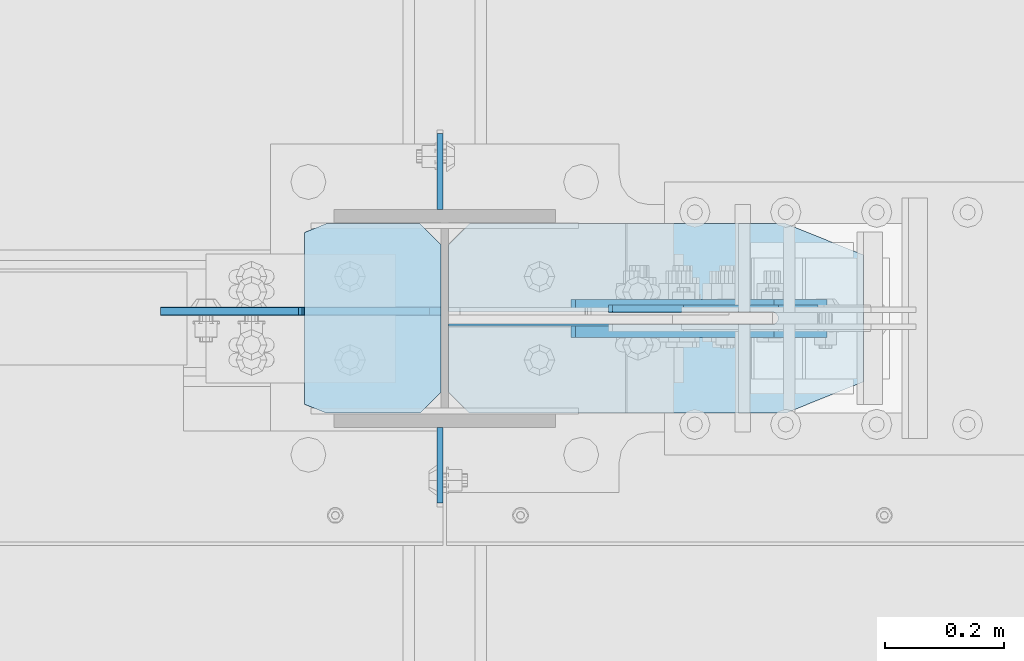
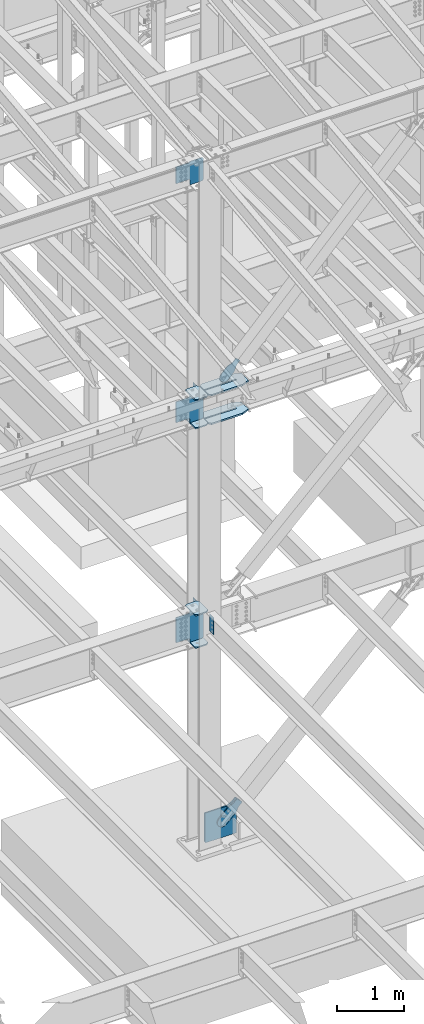
# One storey, part 1028 of 1179: 16 plates, 4 elements without a shape of their own.
"""IFC2X3 building model written with IfcOpenShell, lengths in millimetres."""

from ifc_helpers import new_model, si_unit, frame, origin_with_axes, place, context, subcontext, project, spatial, faceted_brep, material, type_object, element, aggregate, save


model = new_model("IFC2X3")

# Units and contexts
model_context = context("Model", 3, precision=1e-05, world=origin_with_axes())
body_context = subcontext(model_context, "Body", "Model", "MODEL_VIEW")
ifc_project = project(units=[si_unit("LENGTHUNIT", "METRE", prefix="MILLI"), si_unit("AREAUNIT", "SQUARE_METRE"), si_unit("VOLUMEUNIT", "CUBIC_METRE"), si_unit("MASSUNIT", "GRAM", prefix="KILO"), si_unit("TIMEUNIT", "SECOND"), si_unit("PLANEANGLEUNIT", "RADIAN"), si_unit("SOLIDANGLEUNIT", "STERADIAN"), si_unit("THERMODYNAMICTEMPERATUREUNIT", "DEGREE_CELSIUS"), si_unit("LUMINOUSINTENSITYUNIT", "LUMEN")], contexts=[model_context])

# Site, building, storey
site_placement = place(None, origin_with_axes())
site = spatial("IfcSite", under=ifc_project, at=site_placement, CompositionType="ELEMENT")
building_placement = place(site_placement, origin_with_axes())
building = spatial("IfcBuilding", under=site, at=building_placement, Name="Undefined", CompositionType="ELEMENT")
storey_placement = place(building_placement, origin_with_axes())
storey = spatial("IfcBuildingStorey", under=building, at=storey_placement, Name="Undefined", CompositionType="ELEMENT", Elevation=0.0)

# Assembly, plates
assembly_1_placement = place(storey_placement, origin_with_axes())
assembly_1 = element("IfcElementAssembly", 1, at=assembly_1_placement, inside=storey, Name="COLUMN", AssemblyPlace="NOTDEFINED", PredefinedType="RIGID_FRAME")
ifc_material_1 = material(Name="STEEL/A36")
plate_type_1 = type_object("IfcPlateType", PredefinedType="NOTDEFINED")
plate_1_placement = place(assembly_1_placement, frame((8272.4625, 27233.5625, 7975.59999886453), z_axis=(0.0, 1.0, 0.0), x_axis=(0.0, 0.0, -1.0)))
plate_1 = element("IfcPlate", 2, at=plate_1_placement, type_object=plate_type_1, material=ifc_material_1, Name="PLATE", context=body_context, shape_type="Brep", body=[
    faceted_brep([(0.0, -4.76249999999709, 0.0), (0.0, -4.76249999999709, 127.0), (0.0, 4.76249999999709, 127.0), (0.0, 4.76249999999709, 0.0), (304.799999999999, -4.76249999999982, 127.0), (304.799999999999, 4.76249999999982, 127.0), (304.799987792969, -4.76250000000073, 0.0), (304.799987792969, 4.76250000000073, 0.0)], [[[0, 1, 2, 3]], [[2, 1, 4, 5]], [[4, 6, 7, 5]], [[6, 0, 3, 7]], [[5, 7, 3, 2]], [[6, 4, 1, 0]]]),
])
plate_2_placement = place(assembly_1_placement, frame((8272.4625, 26868.4375, 4063.99999886453), z_axis=(0.0, -1.0, 0.0), x_axis=(0.0, 0.0, -1.0)))
plate_2 = element("IfcPlate", 3, at=plate_2_placement, type_object=plate_type_1, material=ifc_material_1, Name="PLATE", context=body_context, shape_type="Brep", body=[
    faceted_brep([(0.0, -4.76249999999709, 0.0), (0.0, -4.76249999999709, 127.0), (0.0, 4.76249999999709, 127.0), (0.0, 4.76249999999709, 0.0), (304.799999999999, -4.76249999999982, 127.0), (304.799999999999, 4.76249999999982, 127.0), (304.799987792969, -4.76250000000073, 0.0), (304.799987792969, 4.76250000000073, 0.0)], [[[0, 1, 2, 3]], [[2, 1, 4, 5]], [[4, 6, 7, 5]], [[6, 0, 3, 7]], [[5, 7, 3, 2]], [[6, 4, 1, 0]]]),
])
plate_3_placement = place(assembly_1_placement, frame((8272.4625, 27233.5625, 4063.99999886453), z_axis=(0.0, 1.0, 0.0), x_axis=(0.0, 0.0, -1.0)))
plate_3 = element("IfcPlate", 4, at=plate_3_placement, type_object=plate_type_1, material=ifc_material_1, Name="PLATE", context=body_context, shape_type="Brep", body=[
    faceted_brep([(0.0, -4.76249999999709, 0.0), (0.0, -4.76250000000073, 127.109008789062), (0.0, 4.76250000000073, 127.109008789062), (0.0, 4.76249999999709, 0.0), (304.799987792969, -4.76250000000073, 127.109008789062), (304.799987792969, 4.76250000000073, 127.109008789062), (304.799987792969, -4.76250000000073, 0.0), (304.799987792969, 4.76250000000073, 0.0)], [[[0, 1, 2, 3]], [[1, 4, 5, 2]], [[4, 6, 7, 5]], [[6, 0, 3, 7]], [[5, 7, 3, 2]], [[6, 4, 1, 0]]]),
])

# Assembly, plate
assembly_2_placement = place(storey_placement, origin_with_axes())
assembly_2 = element("IfcElementAssembly", 5, at=assembly_2_placement, inside=storey, AssemblyPlace="NOTDEFINED", PredefinedType="RIGID_FRAME")
plate_type_2 = type_object("IfcPlateType", PredefinedType="NOTDEFINED")
plate_4_placement = place(assembly_2_placement, frame((8848.95548700398, 27066.875, 8270.04204745431), z_axis=(-0.724386095169387, 0.0, 0.689394506161203), x_axis=(0.689394506161203, 0.0, 0.724386095169387)))
plate_4 = element("IfcPlate", 6, at=plate_4_placement, type_object=plate_type_2, material=ifc_material_1, context=body_context, shape_type="Brep", body=[
    faceted_brep([(0.0, -6.34999999999854, 0.0), (-101.600000000211, -6.34999999999854, -44.6881937825565), (-101.600000000211, 6.34999999999854, -44.6881937825565), (0.0, 6.34999999999854, 0.0), (-246.684985848258, -6.34999999999854, -44.6881937827675), (-246.684985848258, 6.34999999999854, -44.6881937827675), (-281.313054102191, -6.34999999999854, -37.800242748639), (-281.313054102191, 6.34999999999854, -37.800242748639), (-310.669312868691, -6.34999999999854, -18.1850177516608), (-310.669312868691, 6.34999999999854, -18.1850177516608), (-330.284537865713, -6.34999999999854, 11.1712410148393), (-330.284537865713, 6.34999999999854, 11.1712410148393), (-337.172488899912, -6.34999999999854, 45.7993031647638), (-337.172488899912, 6.34999999999854, 45.7993031647638), (-330.284537865768, -6.34999999999854, 80.4273714187839), (-330.284537865768, 6.34999999999854, 80.4273714187839), (-310.669312868773, -6.34999999999854, 109.783630185371), (-310.669312868773, 6.34999999999854, 109.783630185371), (-281.313054102271, -6.34999999999854, 129.398855182466), (-281.313054102271, 6.34999999999854, 129.398855182466), (-246.684988899762, -6.34999999999854, 136.286806216707), (-246.684988899762, 6.34999999999854, 136.286806216707), (-101.600000000377, -6.34999999999854, 136.286806216911), (-101.600000000377, 6.34999999999854, 136.286806216911), (-8.18545231595635e-11, -6.34999999999854, 91.5986124346418), (-8.18545231595635e-11, 6.34999999999854, 91.5986124346418), (82.5500000001266, -6.34999999999854, 91.5986124347546), (82.5500000001266, 6.34999999999854, 91.5986124347546), (82.550000000203, -6.34999999999854, 1.2732925824821e-10), (82.550000000203, 6.34999999999854, 1.2732925824821e-10)], [[[0, 1, 2, 3]], [[1, 4, 5, 2]], [[4, 6, 7, 5]], [[6, 8, 9, 7]], [[8, 10, 11, 9]], [[10, 12, 13, 11]], [[12, 14, 15, 13]], [[14, 16, 17, 15]], [[16, 18, 19, 17]], [[18, 20, 21, 19]], [[20, 22, 23, 21]], [[22, 24, 25, 23]], [[24, 26, 27, 25]], [[26, 28, 29, 27]], [[28, 0, 3, 29]], [[5, 7, 9, 11, 13, 15, 17, 19, 21, 23, 25, 27, 29, 3, 2]], [[28, 26, 24, 22, 20, 18, 16, 14, 12, 10, 8, 6, 4, 1, 0]]]),
])
aggregate(assembly_2, [plate_4])

# Plate
ifc_material_2 = material(Name="STEEL/A572-GR.50")
plate_type_3 = type_object("IfcPlateType", PredefinedType="NOTDEFINED")
plate_5_placement = place(assembly_1_placement, frame((8045.45, 27209.75, 7491.4125), z_axis=(0.0, -1.0, 0.0), x_axis=(1.0, 0.0, 0.0)))
plate_5 = element("IfcPlate", 7, at=plate_5_placement, type_object=plate_type_3, material=ifc_material_2, Name="PLATE", context=body_context, shape_type="Brep", body=[
    faceted_brep([(36.5125000000007, -11.1124999999993, 0.0), (0.0, -11.1124999999993, 14.6049999999996), (0.0, 11.1124999999993, 14.6049999999996), (36.5125000000007, 11.1124999999993, 0.0), (36.5125000000007, -11.1124999999993, 317.5), (36.5125000000007, 11.1124999999993, 317.5), (0.0, 11.1124999999993, 302.895), (0.0, -11.1124999999993, 302.895), (193.675000762942, -11.1124999999993, 317.5), (193.675000762942, 11.1124999999993, 317.5), (228.600000000002, -11.1124999999993, 282.575000762939), (228.600000000002, 11.1124999999993, 282.575000762939), (228.600000000002, -11.1124999999993, 34.9249992370605), (228.600000000002, 11.1124999999993, 34.9249992370605), (193.675000762942, -11.1124999999993, 0.0), (193.675000762942, 11.1124999999993, 0.0)], [[[0, 1, 2, 3]], [[4, 5, 6, 7]], [[8, 9, 5, 4]], [[8, 10, 11, 9]], [[10, 12, 13, 11]], [[12, 14, 15, 13]], [[15, 14, 0, 3]], [[6, 5, 9, 11, 13, 15, 3, 2]], [[7, 6, 2, 1]], [[14, 12, 10, 8, 4, 7, 1, 0]]]),
])

plate_6_placement = place(assembly_1_placement, frame((8045.45, 27209.75, 8002.5875), z_axis=(0.0, -1.0, 0.0), x_axis=(1.0, 0.0, 0.0)))
plate_6 = element("IfcPlate", 8, at=plate_6_placement, type_object=plate_type_3, material=ifc_material_2, Name="PLATE", context=body_context, shape_type="Brep", body=[
    faceted_brep([(36.5125000000007, -11.1124999999993, 0.0), (0.0, -11.1124999999993, 14.6049999999996), (0.0, 11.1124999999993, 14.6049999999996), (36.5125000000007, 11.1124999999993, 0.0), (36.5125000000007, -11.1124999999993, 317.5), (36.5125000000007, 11.1124999999993, 317.5), (0.0, 11.1124999999993, 302.895), (0.0, -11.1124999999993, 302.895), (193.675000762942, -11.1124999999993, 317.5), (193.675000762942, 11.1124999999993, 317.5), (228.600000000002, -11.1124999999993, 282.575000762939), (228.600000000002, 11.1124999999993, 282.575000762939), (228.600000000002, -11.1124999999993, 34.9249992370605), (228.600000000002, 11.1124999999993, 34.9249992370605), (193.675000762942, -11.1124999999993, 0.0), (193.675000762942, 11.1124999999993, 0.0)], [[[0, 1, 2, 3]], [[4, 5, 6, 7]], [[8, 9, 5, 4]], [[8, 10, 11, 9]], [[10, 12, 13, 11]], [[12, 14, 15, 13]], [[15, 14, 0, 3]], [[6, 5, 9, 11, 13, 15, 3, 2]], [[7, 6, 2, 1]], [[14, 12, 10, 8, 4, 7, 1, 0]]]),
])

plate_7_placement = place(assembly_1_placement, frame((8045.45, 27209.75, 3500.4375), z_axis=(0.0, -1.0, 0.0), x_axis=(1.0, 0.0, 0.0)))
plate_7 = element("IfcPlate", 9, at=plate_7_placement, type_object=plate_type_3, material=ifc_material_2, Name="PLATE", context=body_context, shape_type="Brep", body=[
    faceted_brep([(36.5125000000007, -11.1124999999993, 0.0), (0.0, -11.1125000000002, 14.979486697699), (0.0, 11.1125000000002, 14.979486697699), (36.5125000000007, 11.1124999999993, 0.0), (36.5125000000007, -11.1124999999993, 317.5), (36.5125000000007, 11.1124999999993, 317.5), (0.0, 11.1125000000002, 302.520512676303), (0.0, -11.1125000000002, 302.520512676303), (193.675000762942, -11.1124999999993, 317.5), (193.675000762942, 11.1124999999993, 317.5), (228.600000000002, -11.1124999999993, 282.575000762939), (228.600000000002, 11.1124999999993, 282.575000762939), (228.600000000002, -11.1124999999993, 34.9249992370605), (228.600000000002, 11.1124999999993, 34.9249992370605), (193.675000762942, -11.1124999999993, 0.0), (193.675000762942, 11.1124999999993, 0.0)], [[[0, 1, 2, 3]], [[4, 5, 6, 7]], [[8, 9, 5, 4]], [[8, 10, 11, 9]], [[10, 12, 13, 11]], [[12, 14, 15, 13]], [[15, 14, 0, 3]], [[6, 5, 9, 11, 13, 15, 3, 2]], [[7, 6, 2, 1]], [[14, 12, 10, 8, 4, 7, 1, 0]]]),
])

plate_8_placement = place(assembly_1_placement, frame((8045.45, 27209.75, 4090.9875), z_axis=(0.0, -1.0, 0.0), x_axis=(1.0, 0.0, 0.0)))
plate_8 = element("IfcPlate", 10, at=plate_8_placement, type_object=plate_type_3, material=ifc_material_2, Name="PLATE", context=body_context, shape_type="Brep", body=[
    faceted_brep([(36.5125000000007, -11.1124999999993, 0.0), (0.0, -11.1125000000002, 14.979486697699), (0.0, 11.1125000000002, 14.979486697699), (36.5125000000007, 11.1124999999993, 0.0), (36.5125000000007, -11.1124999999993, 317.5), (36.5125000000007, 11.1124999999993, 317.5), (0.0, 11.1125000000002, 302.520512676303), (0.0, -11.1125000000002, 302.520512676303), (193.675000762942, -11.1124999999993, 317.5), (193.675000762942, 11.1124999999993, 317.5), (228.600000000002, -11.1124999999993, 282.575000762939), (228.600000000002, 11.1124999999993, 282.575000762939), (228.600000000002, -11.1124999999993, 34.9249992370605), (228.600000000002, 11.1124999999993, 34.9249992370605), (193.675000762942, -11.1124999999993, 0.0), (193.675000762942, 11.1124999999993, 0.0)], [[[0, 1, 2, 3]], [[4, 5, 6, 7]], [[8, 9, 5, 4]], [[8, 10, 11, 9]], [[10, 12, 13, 11]], [[12, 14, 15, 13]], [[15, 14, 0, 3]], [[6, 5, 9, 11, 13, 15, 3, 2]], [[7, 6, 2, 1]], [[14, 12, 10, 8, 4, 7, 1, 0]]]),
])

plate_type_4 = type_object("IfcPlateType", PredefinedType="NOTDEFINED")
plate_9_placement = place(assembly_1_placement, frame((8274.04999661162, 27062.9062499701, 11843.9406250357), z_axis=(-0.707106781186532, 0.0, 0.707106781186563), x_axis=(-0.707106781186564, 0.0, -0.707106781186531)))
plate_9 = element("IfcPlate", 11, at=plate_9_placement, type_object=plate_type_4, material=ifc_material_2, Name="PLATE", context=body_context, shape_type="Brep", body=[
    faceted_brep([(0.0, -6.34999999999854, 0.0), (-271.652749686205, -6.35000000000036, 271.652745638487), (-271.652749686205, 6.35000000000036, 271.652745638487), (0.0, 6.34999999999854, 0.0), (-271.652749686187, -6.35000000000036, 298.59351380097), (-271.652749686187, 6.35000000000036, 298.59351380097), (-123.478521665553, -6.34999999999854, 446.767742022512), (-123.478521665553, 6.34999999999854, 446.767742022512), (-118.32830100301, -6.34999999999854, 443.326474595233), (-118.32830100301, 6.34999999999854, 443.326474595233), (-112.253201514221, -6.34999999999854, 442.118062173842), (-112.253201514221, 6.34999999999854, 442.118062173842), (-106.178102025433, -6.34999999999854, 443.326474595215), (-106.178102025433, 6.34999999999854, 443.326474595215), (-101.027881362903, -6.34999999999854, 446.767742022486), (-101.027881362903, 6.34999999999854, 446.767742022486), (58.3716647852852, -6.34999999999854, 606.167288170658), (58.3716647852852, 6.34999999999854, 606.167288170658), (273.897811691008, -6.34999999999854, 390.641141264914), (273.897811691008, 6.34999999999854, 390.641141264914), (121.233457363867, -6.34999999999854, 237.976786937787), (121.233457363867, 6.34999999999854, 237.976786937787), (115.727429562927, -6.34999999999854, 229.736434001497), (115.727429562927, 6.34999999999854, 229.736434001497), (113.793969717764, -6.34999999999854, 220.016274965419), (113.793969717764, 6.34999999999854, 220.016274965419), (115.727429562949, -6.34999999999854, 210.296115929337), (115.727429562949, 6.34999999999854, 210.296115929337), (121.233457363913, -6.34999999999854, 202.05576299303), (121.233457363913, 6.34999999999854, 202.05576299303), (175.114994360907, -6.34999999999854, 148.174225997692), (175.114994360907, 6.34999999999854, 148.174225997692), (26.9407683631471, -6.34999999999854, -6.91215973347425e-11), (26.9407683631471, 6.34999999999854, -6.91215973347425e-11)], [[[0, 1, 2, 3]], [[1, 4, 5, 2]], [[4, 6, 7, 5]], [[6, 8, 9, 7]], [[8, 10, 11, 9]], [[10, 12, 13, 11]], [[12, 14, 15, 13]], [[14, 16, 17, 15]], [[16, 18, 19, 17]], [[18, 20, 21, 19]], [[20, 22, 23, 21]], [[22, 24, 25, 23]], [[24, 26, 27, 25]], [[26, 28, 29, 27]], [[28, 30, 31, 29]], [[30, 32, 33, 31]], [[32, 0, 3, 33]], [[5, 7, 9, 11, 13, 15, 17, 19, 21, 23, 25, 27, 29, 31, 33, 3, 2]], [[32, 30, 28, 26, 24, 22, 20, 18, 16, 14, 12, 10, 8, 6, 4, 1, 0]]]),
])

plate_type_5 = type_object("IfcPlateType", PredefinedType="NOTDEFINED")
plate_10_placement = place(assembly_1_placement, frame((8982.08391818748, 27209.75, 7999.4125), z_axis=(-1.0, 0.0, 0.0), x_axis=(0.0, -1.0, 0.0)))
plate_10 = element("IfcPlate", 12, at=plate_10_placement, type_object=plate_type_5, material=ifc_material_2, Name="PLATE", context=body_context, shape_type="Brep", body=[
    faceted_brep([(147.637499999997, -14.2875000000004, 695.33391818764), (147.637499999997, -14.2875000000004, 153.987500190735), (147.637499999997, 14.2875000000004, 153.987500190735), (147.637499999997, 14.2875000000004, 695.33391818764), (148.483388709483, -14.2875000000004, 149.734930475586), (148.483388709483, 14.2875000000004, 149.734930475586), (150.892275949926, -14.2875000000004, 146.12977594993), (150.892275949926, 14.2875000000004, 146.12977594993), (154.497430475585, -14.2875000000004, 143.720888709488), (154.497430475585, 14.2875000000004, 143.720888709488), (158.750000190732, -14.2875000000004, 142.875), (158.750000190732, 14.2875000000004, 142.875), (158.315276621779, -14.2875000000004, 142.875), (158.315276621779, 14.2875000000004, 142.875), (162.567846336926, -14.2875000000004, 143.720888709488), (162.567846336926, 14.2875000000004, 143.720888709488), (166.173000862585, -14.2875000000004, 146.12977594993), (166.173000862585, 14.2875000000004, 146.12977594993), (168.581888103028, -14.2875000000004, 149.734930475586), (168.581888103028, 14.2875000000004, 149.734930475586), (169.427776812514, -14.2875000000004, 153.987500190735), (169.427776812514, 14.2875000000004, 153.987500190735), (169.427776812514, -14.2875000000004, 695.33391818764), (169.427776812514, 14.2875000000004, 695.33391818764), (0.0, -14.2875000000004, 660.408918950579), (34.9249992370605, -14.2875000000004, 695.33391818764), (34.9249992370605, 14.2875000000004, 695.33391818764), (0.0, 14.2875000000004, 660.408918950579), (0.0, -14.2875000000004, 130.175003051758), (0.0, 14.2875000000004, 130.175003051758), (52.3875007629395, -14.2875000000004, 0.0), (52.3875007629395, 14.2875000000004, 0.0), (265.112499237061, -14.2875000000004, 0.0), (265.112499237061, 14.2875000000004, 0.0), (317.5, -14.2875000000004, 130.175003051758), (317.5, 14.2875000000004, 130.175003051758), (317.5, -14.2875000000004, 660.408918950579), (317.5, 14.2875000000004, 660.408918950579), (282.575000762939, -14.2875000000004, 695.33391818764), (282.575000762939, 14.2875000000004, 695.33391818764)], [[[0, 1, 2, 3]], [[4, 5, 2, 1]], [[6, 7, 5, 4]], [[8, 9, 7, 6]], [[10, 11, 9, 8]], [[12, 13, 11, 10]], [[14, 15, 13, 12]], [[16, 17, 15, 14]], [[18, 19, 17, 16]], [[20, 21, 19, 18]], [[22, 23, 21, 20]], [[24, 25, 26, 27]], [[28, 24, 27, 29]], [[30, 28, 29, 31]], [[32, 30, 31, 33]], [[34, 32, 33, 35]], [[36, 34, 35, 37]], [[38, 36, 37, 39]], [[18, 16, 14, 12, 10, 8, 6, 4, 1, 0, 25, 24, 28, 30, 32, 34, 36, 38, 22, 20]], [[26, 25, 0, 3]], [[39, 37, 35, 33, 31, 29, 27, 26, 3, 2, 5, 7, 9, 11, 13, 15, 17, 19, 21, 23]], [[38, 39, 23, 22]]]),
])

plate_11_placement = place(assembly_1_placement, frame((8982.08391818749, 27209.75, 7478.7125), z_axis=(-1.0, 0.0, 0.0), x_axis=(0.0, -1.0, 0.0)))
plate_11 = element("IfcPlate", 13, at=plate_11_placement, type_object=plate_type_5, material=ifc_material_2, Name="PLATE", context=body_context, shape_type="Brep", body=[
    faceted_brep([(147.637499999997, -14.2875000000004, 695.33391818764), (147.637499999997, -14.2875000000004, 153.987500190735), (147.637499999997, 14.2875000000004, 153.987500190735), (147.637499999997, 14.2875000000004, 695.33391818764), (148.483388709483, -14.2875000000004, 149.734930475586), (148.483388709483, 14.2875000000004, 149.734930475586), (150.892275949926, -14.2875000000004, 146.12977594993), (150.892275949926, 14.2875000000004, 146.12977594993), (154.497430475585, -14.2875000000004, 143.720888709488), (154.497430475585, 14.2875000000004, 143.720888709488), (158.750000190732, -14.2875000000004, 142.875), (158.750000190732, 14.2875000000004, 142.875), (158.315276621779, -14.2875000000004, 142.875), (158.315276621779, 14.2875000000004, 142.875), (162.567846336926, -14.2875000000004, 143.720888709488), (162.567846336926, 14.2875000000004, 143.720888709488), (166.173000862585, -14.2875000000004, 146.12977594993), (166.173000862585, 14.2875000000004, 146.12977594993), (168.581888103028, -14.2875000000004, 149.734930475586), (168.581888103028, 14.2875000000004, 149.734930475586), (169.427776812514, -14.2875000000004, 153.987500190735), (169.427776812514, 14.2875000000004, 153.987500190735), (169.427776812514, -14.2875000000004, 695.33391818764), (169.427776812514, 14.2875000000004, 695.33391818764), (0.0, -14.2875000000004, 660.408918950579), (34.9249992370605, -14.2875000000004, 695.33391818764), (34.9249992370605, 14.2875000000004, 695.33391818764), (0.0, 14.2875000000004, 660.408918950579), (0.0, -14.2875000000004, 130.175003051758), (0.0, 14.2875000000004, 130.175003051758), (52.3875007629395, -14.2875000000004, 0.0), (52.3875007629395, 14.2875000000004, 0.0), (265.112499237061, -14.2875000000004, 0.0), (265.112499237061, 14.2875000000004, 0.0), (317.5, -14.2875000000004, 130.175003051758), (317.5, 14.2875000000004, 130.175003051758), (317.5, -14.2875000000004, 660.408918950579), (317.5, 14.2875000000004, 660.408918950579), (282.575000762939, -14.2875000000004, 695.33391818764), (282.575000762939, 14.2875000000004, 695.33391818764)], [[[0, 1, 2, 3]], [[4, 5, 2, 1]], [[6, 7, 5, 4]], [[8, 9, 7, 6]], [[10, 11, 9, 8]], [[12, 13, 11, 10]], [[14, 15, 13, 12]], [[16, 17, 15, 14]], [[18, 19, 17, 16]], [[20, 21, 19, 18]], [[22, 23, 21, 20]], [[24, 25, 26, 27]], [[28, 24, 27, 29]], [[30, 28, 29, 31]], [[32, 30, 31, 33]], [[34, 32, 33, 35]], [[36, 34, 35, 37]], [[38, 36, 37, 39]], [[18, 16, 14, 12, 10, 8, 6, 4, 1, 0, 25, 24, 28, 30, 32, 34, 36, 38, 22, 20]], [[26, 25, 0, 3]], [[39, 37, 35, 33, 31, 29, 27, 26, 3, 2, 5, 7, 9, 11, 13, 15, 17, 19, 21, 23]], [[38, 39, 23, 22]]]),
])

plate_type_6 = type_object("IfcPlateType", PredefinedType="NOTDEFINED")
plate_12_placement = place(assembly_1_placement, frame((8274.04999454697, 27062.1125, 7521.575), z_axis=(-0.707106781186532, 0.0, 0.707106781186563), x_axis=(-0.707106781186564, 0.0, -0.707106781186531)))
plate_12 = element("IfcPlate", 14, at=plate_12_placement, type_object=plate_type_6, material=ifc_material_2, Name="PLATE", context=body_context, shape_type="Brep", body=[
    faceted_brep([(0.0, -6.34999999999854, 0.0), (-318.799092298076, -6.34999999999854, 318.799092298053), (-318.799092298076, 6.34999999999854, 318.799092298053), (0.0, 6.34999999999854, 0.0), (-318.799092298147, -6.34999999999854, 345.739860661201), (-318.799092298147, 6.34999999999854, 345.739860661201), (-170.624866301226, -6.34999999999854, 493.914086658137), (-170.624866301226, 6.34999999999854, 493.914086658137), (-168.379802001214, -6.34999999999854, 491.669022358128), (-168.379802001214, 6.34999999999854, 491.669022358128), (-160.139449064909, -6.34999999999854, 486.162994557169), (-160.139449064909, 6.34999999999854, 486.162994557169), (-150.419290028824, -6.34999999999854, 484.229534711983), (-150.419290028824, 6.34999999999854, 484.229534711983), (-140.699130992749, -6.34999999999854, 486.162994557144), (-140.699130992749, 6.34999999999854, 486.162994557144), (-132.458778056457, -6.34999999999854, 491.669022358081), (-132.458778056457, 6.34999999999854, 491.669022358081), (20.2055762706732, -6.34999999999854, 644.333376685223), (20.2055762706732, 6.34999999999854, 644.333376685223), (289.613259902851, -6.34999999999854, 374.925693053072), (289.613259902851, 6.34999999999854, 374.925693053072), (136.948905575722, -6.34999999999854, 222.261338725926), (136.948905575722, 6.34999999999854, 222.261338725926), (131.442877774783, -6.34999999999854, 214.020985789637), (131.442877774783, 6.34999999999854, 214.020985789637), (129.509417929622, -6.34999999999854, 204.300826753559), (129.509417929622, 6.34999999999854, 204.300826753559), (131.442877774809, -6.34999999999854, 194.580667717477), (131.442877774809, 6.34999999999854, 194.580667717477), (136.948905575769, -6.34999999999854, 186.340314781173), (136.948905575769, 6.34999999999854, 186.340314781173), (175.114994360907, -6.34999999999854, 148.174225997692), (175.114994360907, 6.34999999999854, 148.174225997692), (26.9407683631471, -6.34999999999854, -6.91215973347425e-11), (26.9407683631471, 6.34999999999854, -6.91215973347425e-11)], [[[0, 1, 2, 3]], [[1, 4, 5, 2]], [[4, 6, 7, 5]], [[6, 8, 9, 7]], [[8, 10, 11, 9]], [[10, 12, 13, 11]], [[12, 14, 15, 13]], [[14, 16, 17, 15]], [[16, 18, 19, 17]], [[18, 20, 21, 19]], [[20, 22, 23, 21]], [[22, 24, 25, 23]], [[24, 26, 27, 25]], [[26, 28, 29, 27]], [[28, 30, 31, 29]], [[30, 32, 33, 31]], [[32, 34, 35, 33]], [[34, 0, 3, 35]], [[5, 7, 9, 11, 13, 15, 17, 19, 21, 23, 25, 27, 29, 31, 33, 35, 3, 2]], [[34, 32, 30, 28, 26, 24, 22, 20, 18, 16, 14, 12, 10, 8, 6, 4, 1, 0]]]),
])

plate_13_placement = place(assembly_1_placement, frame((8274.04999260104, 27063.7, 3530.6), z_axis=(-0.707106781186532, 0.0, 0.707106781186563), x_axis=(-0.707106781186564, 0.0, -0.707106781186531)))
plate_13 = element("IfcPlate", 15, at=plate_13_placement, type_object=plate_type_6, material=ifc_material_2, Name="PLATE", context=body_context, shape_type="Brep", body=[
    faceted_brep([(0.0, -6.34999999999854, 0.0), (-374.925693054754, -6.34999999999854, 374.925693054773), (-374.925693054754, 6.34999999999854, 374.925693054773), (0.0, 6.34999999999854, 0.0), (-374.925693054789, -6.34999999999854, 401.866461417955), (-374.925693054789, 6.34999999999854, 401.866461417955), (-226.751467057473, -6.34999999999854, 550.040687415264), (-226.751467057473, 6.34999999999854, 550.040687415264), (-215.52614663639, -6.34999999999854, 538.815366994181), (-215.52614663639, 6.34999999999854, 538.815366994181), (-207.285793700081, -6.34999999999854, 533.309339193224), (-207.285793700081, 6.34999999999854, 533.309339193224), (-197.565634663988, -6.34999999999854, 531.375879348047), (-197.565634663988, 6.34999999999854, 531.375879348047), (-187.845475627895, -6.34999999999854, 533.309339193224), (-187.845475627895, 6.34999999999854, 533.309339193224), (-179.605122691586, -6.34999999999854, 538.81536699418), (-179.605122691586, 6.34999999999854, 538.81536699418), (-26.9407683640547, -6.34999999999854, 691.479721321704), (-26.9407683640547, 6.34999999999854, 691.479721321704), (296.348451994538, -6.34999999999854, 368.190500963096), (296.348451994538, 6.34999999999854, 368.190500963096), (143.684097667006, -6.34999999999854, 215.526146635572), (143.684097667006, 6.34999999999854, 215.526146635572), (138.178069866048, -6.34999999999854, 207.285793699265), (138.178069866048, 6.34999999999854, 207.285793699265), (136.244610020873, -6.34999999999854, 197.565634663171), (136.244610020873, 6.34999999999854, 197.565634663171), (138.178069866048, -6.34999999999854, 187.845475627078), (138.178069866048, 6.34999999999854, 187.845475627078), (143.684097667005, -6.34999999999854, 179.605122690769), (143.684097667005, 6.34999999999854, 179.605122690769), (175.114994360907, -6.34999999999854, 148.174225997692), (175.114994360907, 6.34999999999854, 148.174225997692), (26.9407683631471, -6.34999999999854, -6.91215973347425e-11), (26.9407683631471, 6.34999999999854, -6.91215973347425e-11)], [[[0, 1, 2, 3]], [[1, 4, 5, 2]], [[4, 6, 7, 5]], [[6, 8, 9, 7]], [[8, 10, 11, 9]], [[10, 12, 13, 11]], [[12, 14, 15, 13]], [[14, 16, 17, 15]], [[16, 18, 19, 17]], [[18, 20, 21, 19]], [[20, 22, 23, 21]], [[22, 24, 25, 23]], [[24, 26, 27, 25]], [[26, 28, 29, 27]], [[28, 30, 31, 29]], [[30, 32, 33, 31]], [[32, 34, 35, 33]], [[34, 0, 3, 35]], [[5, 7, 9, 11, 13, 15, 17, 19, 21, 23, 25, 27, 29, 31, 33, 35, 3, 2]], [[34, 32, 30, 28, 26, 24, 22, 20, 18, 16, 14, 12, 10, 8, 6, 4, 1, 0]]]),
])

# Assembly, plate
assembly_3_placement = place(storey_placement, origin_with_axes())
assembly_3 = element("IfcElementAssembly", 16, at=assembly_3_placement, inside=storey, AssemblyPlace="NOTDEFINED", PredefinedType="RIGID_FRAME")
plate_type_7 = type_object("IfcPlateType", PredefinedType="NOTDEFINED")
plate_14_placement = place(assembly_3_placement, frame((8861.99411883337, 27073.225, 265.034556160026), z_axis=(-0.699860687134476, 0.0, 0.714279370137245), x_axis=(0.714279370137245, 0.0, 0.699860687134476)))
plate_14 = element("IfcPlate", 17, at=plate_14_placement, type_object=plate_type_7, material=ifc_material_1, context=body_context, shape_type="Brep", body=[
    faceted_brep([(0.0, -9.52499999999964, 0.0), (-101.600000000087, -9.52500000000146, -33.3242722112027), (-101.600000000087, 9.52500000000146, -33.3242722112027), (0.0, 9.52499999999964, 0.0), (-320.279297672004, -9.52500000000146, -33.3242722113773), (-320.279297672004, 9.52500000000146, -33.3242722113773), (-357.337405137497, -9.52500000000146, -25.9529563248489), (-357.337405137497, 9.52500000000146, -25.9529563248489), (-388.753751673986, -9.52500000000146, -4.96122468778412), (-388.753751673986, 9.52500000000146, -4.96122468778412), (-409.745483311205, -9.52500000000146, 26.4551218486158), (-409.745483311205, 9.52500000000146, 26.4551218486158), (-417.116799197928, -9.52500000000146, 63.5132262625084), (-417.116799197928, 9.52500000000146, 63.5132262625084), (-409.745483311476, -9.52500000000146, 100.57133372822), (-409.745483311476, 9.52500000000146, 100.57133372822), (-388.753751674353, -9.52500000000146, 131.987680264896), (-388.753751674353, 9.52500000000146, 131.987680264896), (-357.337405137807, -9.52500000000146, 152.979411902199), (-357.337405137807, 9.52500000000146, 152.979411902199), (-320.279299198141, -9.52500000000146, 160.350727788849), (-320.279299198141, 9.52500000000146, 160.350727788849), (-101.60000000096, -9.52500000000146, 160.35072778902), (-101.60000000096, 9.52500000000146, 160.35072778902), (-5.72072167415172e-10, -9.52500000000146, 127.026455577978), (-5.72072167415172e-10, 9.52500000000146, 127.026455577978), (82.5499999996218, -9.52500000000146, 127.02645557804), (82.5499999996218, 9.52500000000146, 127.02645557804), (82.5499999997119, -9.52500000000146, 1.81898940354586e-11), (82.5499999997119, 9.52500000000146, 1.81898940354586e-11)], [[[0, 1, 2, 3]], [[1, 4, 5, 2]], [[4, 6, 7, 5]], [[6, 8, 9, 7]], [[8, 10, 11, 9]], [[10, 12, 13, 11]], [[12, 14, 15, 13]], [[14, 16, 17, 15]], [[16, 18, 19, 17]], [[18, 20, 21, 19]], [[20, 22, 23, 21]], [[22, 24, 25, 23]], [[24, 26, 27, 25]], [[26, 28, 29, 27]], [[28, 0, 3, 29]], [[5, 7, 9, 11, 13, 15, 17, 19, 21, 23, 25, 27, 29, 3, 2]], [[28, 26, 24, 22, 20, 18, 16, 14, 12, 10, 8, 6, 4, 1, 0]]]),
])
aggregate(assembly_3, [plate_14])

assembly_4_placement = place(storey_placement, origin_with_axes())
assembly_4 = element("IfcElementAssembly", 18, at=assembly_4_placement, inside=storey, AssemblyPlace="NOTDEFINED", PredefinedType="RIGID_FRAME")
plate_15_placement = place(assembly_4_placement, frame((8861.99411883337, 27028.775, 265.034556160026), z_axis=(-0.699860687134476, 0.0, 0.714279370137245), x_axis=(0.714279370137245, 0.0, 0.699860687134476)))
plate_15 = element("IfcPlate", 19, at=plate_15_placement, type_object=plate_type_7, material=ifc_material_1, context=body_context, shape_type="Brep", body=[
    faceted_brep([(0.0, -9.52499999999964, 0.0), (-101.600000000087, -9.52500000000146, -33.3242722112027), (-101.600000000087, 9.52500000000146, -33.3242722112027), (0.0, 9.52499999999964, 0.0), (-320.279297672004, -9.52500000000146, -33.3242722113773), (-320.279297672004, 9.52500000000146, -33.3242722113773), (-357.337405137497, -9.52500000000146, -25.9529563248489), (-357.337405137497, 9.52500000000146, -25.9529563248489), (-388.753751673986, -9.52500000000146, -4.96122468778412), (-388.753751673986, 9.52500000000146, -4.96122468778412), (-409.745483311205, -9.52500000000146, 26.4551218486158), (-409.745483311205, 9.52500000000146, 26.4551218486158), (-417.116799197928, -9.52500000000146, 63.5132262625084), (-417.116799197928, 9.52500000000146, 63.5132262625084), (-409.745483311476, -9.52500000000146, 100.57133372822), (-409.745483311476, 9.52500000000146, 100.57133372822), (-388.753751674353, -9.52500000000146, 131.987680264896), (-388.753751674353, 9.52500000000146, 131.987680264896), (-357.337405137807, -9.52500000000146, 152.979411902199), (-357.337405137807, 9.52500000000146, 152.979411902199), (-320.279299198141, -9.52500000000146, 160.350727788849), (-320.279299198141, 9.52500000000146, 160.350727788849), (-101.60000000096, -9.52500000000146, 160.35072778902), (-101.60000000096, 9.52500000000146, 160.35072778902), (-5.72072167415172e-10, -9.52500000000146, 127.026455577978), (-5.72072167415172e-10, 9.52500000000146, 127.026455577978), (82.5499999996218, -9.52500000000146, 127.02645557804), (82.5499999996218, 9.52500000000146, 127.02645557804), (82.5499999997119, -9.52500000000146, 1.81898940354586e-11), (82.5499999997119, 9.52500000000146, 1.81898940354586e-11)], [[[0, 1, 2, 3]], [[1, 4, 5, 2]], [[4, 6, 7, 5]], [[6, 8, 9, 7]], [[8, 10, 11, 9]], [[10, 12, 13, 11]], [[12, 14, 15, 13]], [[14, 16, 17, 15]], [[16, 18, 19, 17]], [[18, 20, 21, 19]], [[20, 22, 23, 21]], [[22, 24, 25, 23]], [[24, 26, 27, 25]], [[26, 28, 29, 27]], [[28, 0, 3, 29]], [[5, 7, 9, 11, 13, 15, 17, 19, 21, 23, 25, 27, 29, 3, 2]], [[28, 26, 24, 22, 20, 18, 16, 14, 12, 10, 8, 6, 4, 1, 0]]]),
])
aggregate(assembly_4, [plate_15])

# Plate
plate_type_8 = type_object("IfcPlateType", PredefinedType="NOTDEFINED")
plate_16_placement = place(assembly_1_placement, frame((8286.75, 27051.0, -215.9), z_axis=(0.0, 0.0, 1.0), x_axis=(1.0, 0.0, 0.0)))
plate_16 = element("IfcPlate", 20, at=plate_16_placement, type_object=plate_type_8, material=ifc_material_2, Name="PLATE", context=body_context, shape_type="Brep", body=[
    faceted_brep([(0.0, -12.7000000000007, 19.0500000000029), (0.0, -12.7000000000007, 542.50662338178), (0.0, 12.7000000000007, 542.50662338178), (0.0, 12.7000000000007, 19.0500000000029), (372.673702658971, -12.7000000000007, 542.50662338178), (372.673702658971, 12.7000000000007, 542.50662338178), (543.772144146171, -12.7000000000007, 367.883174367477), (543.772144146171, 12.7000000000007, 367.883174367477), (543.772144146171, -12.7000000000007, 0.0), (543.772144146171, 12.7000000000007, 0.0), (19.0499992370605, -12.6999999999971, 0.0), (19.0499992370605, 12.6999999999971, 0.0)], [[[0, 1, 2, 3]], [[1, 4, 5, 2]], [[4, 6, 7, 5]], [[6, 8, 9, 7]], [[8, 10, 11, 9]], [[10, 0, 3, 11]], [[5, 7, 9, 11, 3, 2]], [[10, 8, 6, 4, 1, 0]]]),
])

aggregate(assembly_1, [plate_9, plate_10, plate_11, plate_16, plate_1, plate_5, plate_6, plate_12, plate_7, plate_8, plate_13, plate_2, plate_3])

save(model, "model.ifc")
